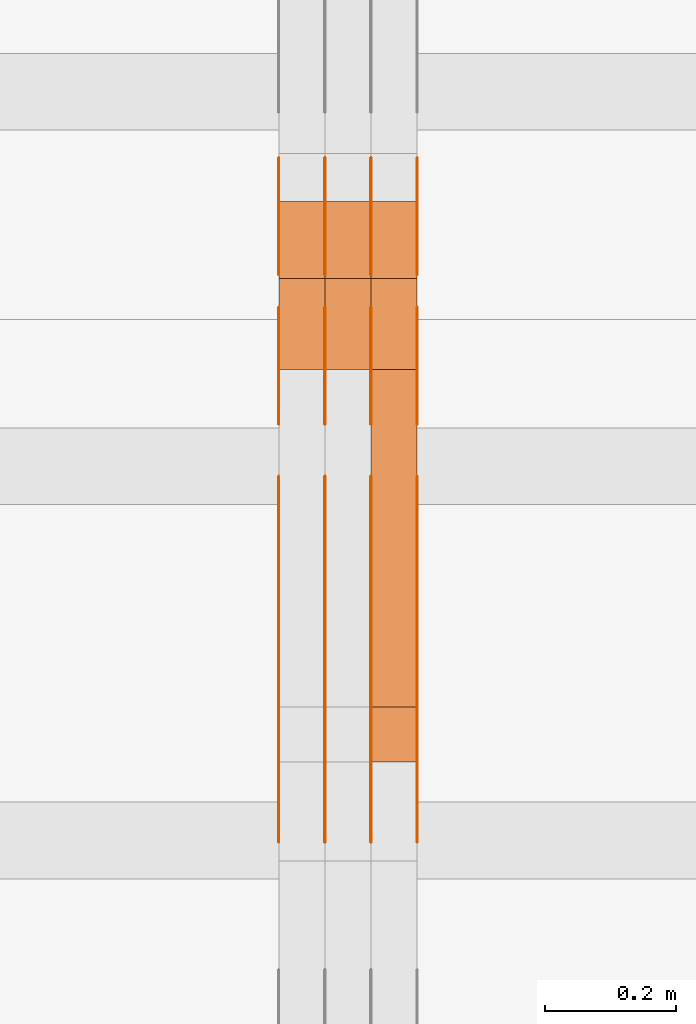
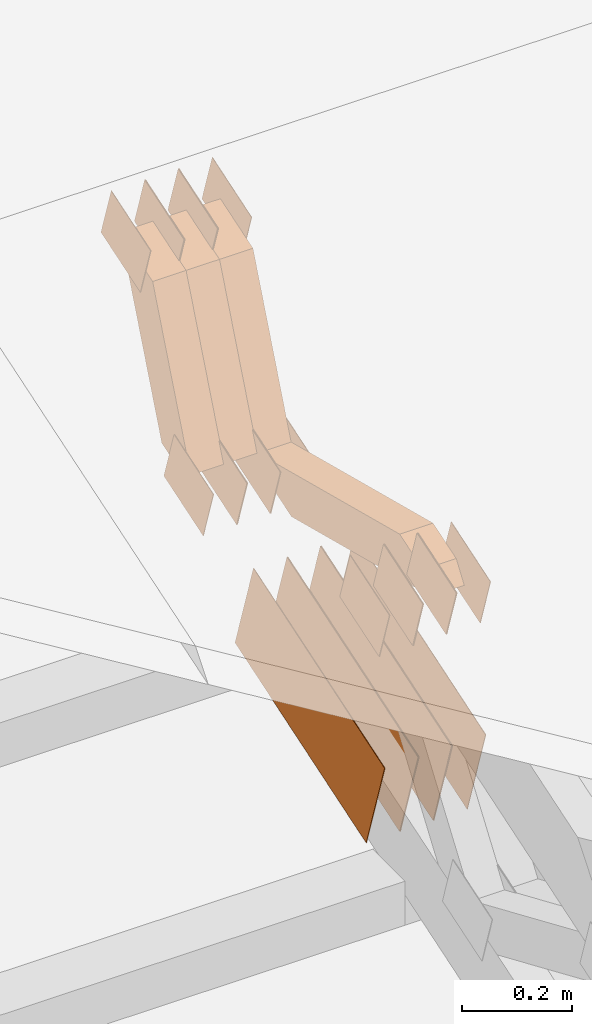
# One storey, part 134 of 385: 28 proxies.
"""IFC2X3 building model written with IfcOpenShell, lengths in millimetres."""

from ifc_helpers import new_model, entity, si_unit, converted_unit, derived_unit, direction, frame, origin, place, context, subcontext, project, spatial, polyline, outline, extrude, source, transform, mapped, material, type_object, type_shapes, element, save


model = new_model("IFC2X3")

# Units and contexts
model_context = context("Model", 3, precision=0.01, world=origin(), true_north=direction((6.12303176911189e-17, 1.0)))
body_context = subcontext(model_context, "Body", "Model", "MODEL_VIEW")
ifc_project = project(units=[si_unit("LENGTHUNIT", "METRE", prefix="MILLI"), si_unit("AREAUNIT", "SQUARE_METRE"), si_unit("VOLUMEUNIT", "CUBIC_METRE"), converted_unit("PLANEANGLEUNIT", "DEGREE", entity("IfcRatioMeasure", 0.0174532925199433), si_unit("PLANEANGLEUNIT", "RADIAN"), dimensions=[0, 0, 0, 0, 0, 0, 0]), si_unit("MASSUNIT", "GRAM", prefix="KILO"), derived_unit("MASSDENSITYUNIT", [(si_unit("MASSUNIT", "GRAM", prefix="KILO"), 1), (si_unit("LENGTHUNIT", "METRE"), -3)]), si_unit("TIMEUNIT", "SECOND"), si_unit("FREQUENCYUNIT", "HERTZ"), si_unit("THERMODYNAMICTEMPERATUREUNIT", "DEGREE_CELSIUS"), derived_unit("THERMALTRANSMITTANCEUNIT", [(si_unit("MASSUNIT", "GRAM", prefix="KILO"), 1), (si_unit("THERMODYNAMICTEMPERATUREUNIT", "KELVIN"), -1), (si_unit("TIMEUNIT", "SECOND"), -3)]), derived_unit("VOLUMETRICFLOWRATEUNIT", [(si_unit("LENGTHUNIT", "METRE"), 3), (si_unit("TIMEUNIT", "SECOND"), -1)]), si_unit("ELECTRICCURRENTUNIT", "AMPERE"), si_unit("ELECTRICVOLTAGEUNIT", "VOLT"), si_unit("POWERUNIT", "WATT"), si_unit("FORCEUNIT", "NEWTON", prefix="KILO"), si_unit("ILLUMINANCEUNIT", "LUX"), si_unit("LUMINOUSFLUXUNIT", "LUMEN"), si_unit("LUMINOUSINTENSITYUNIT", "CANDELA"), derived_unit("USERDEFINED", [(si_unit("MASSUNIT", "GRAM", prefix="KILO"), -1), (si_unit("LENGTHUNIT", "METRE"), -2), (si_unit("TIMEUNIT", "SECOND"), 3), (si_unit("LUMINOUSFLUXUNIT", "LUMEN"), 1)]), derived_unit("LINEARVELOCITYUNIT", [(si_unit("LENGTHUNIT", "METRE"), 1), (si_unit("TIMEUNIT", "SECOND"), -1)]), si_unit("PRESSUREUNIT", "PASCAL"), derived_unit("USERDEFINED", [(si_unit("LENGTHUNIT", "METRE"), -2), (si_unit("MASSUNIT", "GRAM", prefix="KILO"), 1), (si_unit("TIMEUNIT", "SECOND"), -2)])], contexts=[model_context])

# Site, building, storey
site_placement = place(None, origin())
site = spatial("IfcSite", under=ifc_project, at=site_placement, CompositionType="ELEMENT")
building_placement = place(site_placement, origin())
building = spatial("IfcBuilding", under=site, at=building_placement, CompositionType="ELEMENT")
storey_placement = place(building_placement, origin())
storey = spatial("IfcBuildingStorey", under=building, at=storey_placement, Name="Default", CompositionType="ELEMENT", Elevation=0.0)

# Proxies
ifc_material_1 = material(Name="IfcSurfaceStyle #350630")
building_element_proxy_type_1 = type_object("IfcBuildingElementProxyType", PredefinedType="NOTDEFINED", material=ifc_material_1)
shared_shape_1 = source(origin(), body_context, "Body", "SweptSolid", [
    extrude(outline(polyline([(-74.9998565677179, -60.000059685226), (74.9998794200128, -60.000059685226), (74.9998565677179, 60.000059685226), (-74.9998794200128, 60.000059685226), (-74.9998565677179, -60.000059685226)])), frame((75.0001976720505, 60.000059685226, 0.0), z_axis=(0.0, 0.0, 1.0), x_axis=(-1.0, 0.0, 0.0)), (0.0, 0.0, 1.0), 1.3),
])
type_shapes(building_element_proxy_type_1, [shared_shape_1])
proxy_1_placement = place(building_placement, frame((27386.3, 8537.53090236182, 1950.11166041942), z_axis=(-1.0, 0.0, 0.0), x_axis=(0.0, 0.951056516295124, 0.309016994375039)))
element("IfcBuildingElementProxy", 1, at=proxy_1_placement, inside=storey, type_object=building_element_proxy_type_1, material=ifc_material_1, context=body_context, shape_type="MappedRepresentation", body=[
    mapped(shared_shape_1, transform((0.0, 0.0, 0.0), scale=1.0)),
])
ifc_material_2 = material(Name="IfcSurfaceStyle #350573")
building_element_proxy_type_2 = type_object("IfcBuildingElementProxyType", PredefinedType="NOTDEFINED", material=ifc_material_2)
shared_shape_2 = source(origin(), body_context, "Body", "SweptSolid", [
    extrude(outline(polyline([(-74.9998565677179, -60.000059685226), (74.9998794200128, -60.000059685226), (74.9998565677179, 60.000059685226), (-74.9998794200128, 60.000059685226), (-74.9998565677179, -60.000059685226)])), frame((75.0001976720505, 60.000059685226, 0.0), z_axis=(0.0, 0.0, 1.0), x_axis=(-1.0, 0.0, 0.0)), (0.0, 0.0, 1.0), 1.3),
])
type_shapes(building_element_proxy_type_2, [shared_shape_2])
proxy_2_placement = place(building_placement, frame((27315.0, 8537.53090236182, 1950.11166041942), z_axis=(-1.0, 0.0, 0.0), x_axis=(0.0, 0.951056516295124, 0.309016994375039)))
element("IfcBuildingElementProxy", 2, at=proxy_2_placement, inside=storey, type_object=building_element_proxy_type_2, material=ifc_material_2, context=body_context, shape_type="MappedRepresentation", body=[
    mapped(shared_shape_2, transform((0.0, 0.0, 0.0), scale=1.0)),
])
ifc_material_3 = material(Name="IfcSurfaceStyle #350516")
building_element_proxy_type_3 = type_object("IfcBuildingElementProxyType", PredefinedType="NOTDEFINED", material=ifc_material_3)
shared_shape_3 = source(origin(), body_context, "Body", "SweptSolid", [
    extrude(outline(polyline([(-74.9998565677179, -60.000059685226), (74.9998794200128, -60.000059685226), (74.9998565677179, 60.000059685226), (-74.9998794200128, 60.000059685226), (-74.9998565677179, -60.000059685226)])), frame((75.0001976720505, 60.000059685226, 0.0), z_axis=(0.0, 0.0, 1.0), x_axis=(-1.0, 0.0, 0.0)), (0.0, 0.0, 1.0), 1.3),
])
type_shapes(building_element_proxy_type_3, [shared_shape_3])
proxy_3_placement = place(building_placement, frame((27316.3, 8537.53090236182, 1950.11166041942), z_axis=(-1.0, 0.0, 0.0), x_axis=(0.0, 0.951056516295124, 0.309016994375039)))
element("IfcBuildingElementProxy", 3, at=proxy_3_placement, inside=storey, type_object=building_element_proxy_type_3, material=ifc_material_3, context=body_context, shape_type="MappedRepresentation", body=[
    mapped(shared_shape_3, transform((0.0, 0.0, 0.0), scale=1.0)),
])
ifc_material_4 = material(Name="IfcSurfaceStyle #350459")
building_element_proxy_type_4 = type_object("IfcBuildingElementProxyType", PredefinedType="NOTDEFINED", material=ifc_material_4)
shared_shape_4 = source(origin(), body_context, "Body", "SweptSolid", [
    extrude(outline(polyline([(-74.9998565677179, -60.000059685226), (74.9998794200128, -60.000059685226), (74.9998565677179, 60.000059685226), (-74.9998794200128, 60.000059685226), (-74.9998565677179, -60.000059685226)])), frame((75.0001976720505, 60.000059685226, 0.0), z_axis=(0.0, 0.0, 1.0), x_axis=(-1.0, 0.0, 0.0)), (0.0, 0.0, 1.0), 1.29999999999999),
])
type_shapes(building_element_proxy_type_4, [shared_shape_4])
proxy_4_placement = place(building_placement, frame((27245.0, 8537.53090236182, 1950.11166041942), z_axis=(-1.0, 0.0, 0.0), x_axis=(0.0, 0.951056516295124, 0.309016994375039)))
element("IfcBuildingElementProxy", 4, at=proxy_4_placement, inside=storey, type_object=building_element_proxy_type_4, material=ifc_material_4, context=body_context, shape_type="MappedRepresentation", body=[
    mapped(shared_shape_4, transform((0.0, 0.0, 0.0), scale=1.0)),
])
ifc_material_5 = material(Name="IfcSurfaceStyle #350402")
building_element_proxy_type_5 = type_object("IfcBuildingElementProxyType", PredefinedType="NOTDEFINED", material=ifc_material_5)
shared_shape_5 = source(origin(), body_context, "Body", "SweptSolid", [
    extrude(outline(polyline([(-74.9998565677179, -60.000059685226), (74.9998794200128, -60.000059685226), (74.9998565677179, 60.000059685226), (-74.9998794200128, 60.000059685226), (-74.9998565677179, -60.000059685226)])), frame((75.0001976720505, 60.000059685226, 0.0), z_axis=(0.0, 0.0, 1.0), x_axis=(-1.0, 0.0, 0.0)), (0.0, 0.0, 1.0), 1.29999999999999),
])
type_shapes(building_element_proxy_type_5, [shared_shape_5])
proxy_5_placement = place(building_placement, frame((27246.3, 8537.53090236182, 1950.11166041942), z_axis=(-1.0, 0.0, 0.0), x_axis=(0.0, 0.951056516295124, 0.309016994375039)))
element("IfcBuildingElementProxy", 5, at=proxy_5_placement, inside=storey, type_object=building_element_proxy_type_5, material=ifc_material_5, context=body_context, shape_type="MappedRepresentation", body=[
    mapped(shared_shape_5, transform((0.0, 0.0, 0.0), scale=1.0)),
])
ifc_material_6 = material(Name="IfcSurfaceStyle #350345")
building_element_proxy_type_6 = type_object("IfcBuildingElementProxyType", PredefinedType="NOTDEFINED", material=ifc_material_6)
shared_shape_6 = source(origin(), body_context, "Body", "SweptSolid", [
    extrude(outline(polyline([(-74.9998565677179, -60.000059685226), (74.9998794200128, -60.000059685226), (74.9998565677179, 60.000059685226), (-74.9998794200128, 60.000059685226), (-74.9998565677179, -60.000059685226)])), frame((75.0001976720505, 60.000059685226, 0.0), z_axis=(0.0, 0.0, 1.0), x_axis=(-1.0, 0.0, 0.0)), (0.0, 0.0, 1.0), 1.29999999999999),
])
type_shapes(building_element_proxy_type_6, [shared_shape_6])
proxy_6_placement = place(building_placement, frame((27175.0, 8537.53090236182, 1950.11166041942), z_axis=(-1.0, 0.0, 0.0), x_axis=(0.0, 0.951056516295124, 0.309016994375039)))
element("IfcBuildingElementProxy", 6, at=proxy_6_placement, inside=storey, type_object=building_element_proxy_type_6, material=ifc_material_6, context=body_context, shape_type="MappedRepresentation", body=[
    mapped(shared_shape_6, transform((0.0, 0.0, 0.0), scale=1.0)),
])
ifc_material_7 = material(Name="IfcSurfaceStyle #350288")
building_element_proxy_type_7 = type_object("IfcBuildingElementProxyType", PredefinedType="NOTDEFINED", material=ifc_material_7)
shared_shape_7 = source(origin(), body_context, "Body", "SweptSolid", [
    extrude(outline(polyline([(-74.9998754286225, -60.0000016373515), (74.9998605591045, -60.0000016373515), (74.9998754286225, 60.0000016373515), (-74.9998605591045, 60.0000016373515), (-74.9998754286225, -60.0000016373515)])), frame((74.9998754286225, 60.0000016373515, 0.0), z_axis=(0.0, 0.0, 1.0), x_axis=(-1.0, 0.0, 0.0)), (0.0, 0.0, 1.0), 1.3),
])
type_shapes(building_element_proxy_type_7, [shared_shape_7])
proxy_7_placement = place(building_placement, frame((27386.3, 8765.47458614632, 2350.86432930304), z_axis=(-1.0, 0.0, 0.0), x_axis=(0.0, 0.951056516295154, 0.309016994374948)))
element("IfcBuildingElementProxy", 7, at=proxy_7_placement, inside=storey, type_object=building_element_proxy_type_7, material=ifc_material_7, context=body_context, shape_type="MappedRepresentation", body=[
    mapped(shared_shape_7, transform((0.0, 0.0, 0.0), scale=1.0)),
])
ifc_material_8 = material(Name="IfcSurfaceStyle #350231")
building_element_proxy_type_8 = type_object("IfcBuildingElementProxyType", PredefinedType="NOTDEFINED", material=ifc_material_8)
shared_shape_8 = source(origin(), body_context, "Body", "SweptSolid", [
    extrude(outline(polyline([(-74.9998754286225, -60.0000016373515), (74.9998605591045, -60.0000016373515), (74.9998754286225, 60.0000016373515), (-74.9998605591045, 60.0000016373515), (-74.9998754286225, -60.0000016373515)])), frame((74.9998754286225, 60.0000016373515, 0.0), z_axis=(0.0, 0.0, 1.0), x_axis=(-1.0, 0.0, 0.0)), (0.0, 0.0, 1.0), 1.3),
])
type_shapes(building_element_proxy_type_8, [shared_shape_8])
proxy_8_placement = place(building_placement, frame((27315.0, 8765.47458614632, 2350.86432930304), z_axis=(-1.0, 0.0, 0.0), x_axis=(0.0, 0.951056516295154, 0.309016994374948)))
element("IfcBuildingElementProxy", 8, at=proxy_8_placement, inside=storey, type_object=building_element_proxy_type_8, material=ifc_material_8, context=body_context, shape_type="MappedRepresentation", body=[
    mapped(shared_shape_8, transform((0.0, 0.0, 0.0), scale=1.0)),
])
ifc_material_9 = material(Name="IfcSurfaceStyle #350174")
building_element_proxy_type_9 = type_object("IfcBuildingElementProxyType", PredefinedType="NOTDEFINED", material=ifc_material_9)
shared_shape_9 = source(origin(), body_context, "Body", "SweptSolid", [
    extrude(outline(polyline([(-74.9998754286225, -60.0000016373515), (74.9998605591045, -60.0000016373515), (74.9998754286225, 60.0000016373515), (-74.9998605591045, 60.0000016373515), (-74.9998754286225, -60.0000016373515)])), frame((74.9998754286225, 60.0000016373515, 0.0), z_axis=(0.0, 0.0, 1.0), x_axis=(-1.0, 0.0, 0.0)), (0.0, 0.0, 1.0), 1.3),
])
type_shapes(building_element_proxy_type_9, [shared_shape_9])
proxy_9_placement = place(building_placement, frame((27316.3, 8765.47458614632, 2350.86432930304), z_axis=(-1.0, 0.0, 0.0), x_axis=(0.0, 0.951056516295154, 0.309016994374948)))
element("IfcBuildingElementProxy", 9, at=proxy_9_placement, inside=storey, type_object=building_element_proxy_type_9, material=ifc_material_9, context=body_context, shape_type="MappedRepresentation", body=[
    mapped(shared_shape_9, transform((0.0, 0.0, 0.0), scale=1.0)),
])
ifc_material_10 = material(Name="IfcSurfaceStyle #350117")
building_element_proxy_type_10 = type_object("IfcBuildingElementProxyType", PredefinedType="NOTDEFINED", material=ifc_material_10)
shared_shape_10 = source(origin(), body_context, "Body", "SweptSolid", [
    extrude(outline(polyline([(-74.9998754286225, -60.0000016373515), (74.9998605591045, -60.0000016373515), (74.9998754286225, 60.0000016373515), (-74.9998605591045, 60.0000016373515), (-74.9998754286225, -60.0000016373515)])), frame((74.9998754286225, 60.0000016373515, 0.0), z_axis=(0.0, 0.0, 1.0), x_axis=(-1.0, 0.0, 0.0)), (0.0, 0.0, 1.0), 1.29999999999999),
])
type_shapes(building_element_proxy_type_10, [shared_shape_10])
proxy_10_placement = place(building_placement, frame((27245.0, 8765.47458614632, 2350.86432930304), z_axis=(-1.0, 0.0, 0.0), x_axis=(0.0, 0.951056516295154, 0.309016994374948)))
element("IfcBuildingElementProxy", 10, at=proxy_10_placement, inside=storey, type_object=building_element_proxy_type_10, material=ifc_material_10, context=body_context, shape_type="MappedRepresentation", body=[
    mapped(shared_shape_10, transform((0.0, 0.0, 0.0), scale=1.0)),
])
ifc_material_11 = material(Name="IfcSurfaceStyle #350060")
building_element_proxy_type_11 = type_object("IfcBuildingElementProxyType", PredefinedType="NOTDEFINED", material=ifc_material_11)
shared_shape_11 = source(origin(), body_context, "Body", "SweptSolid", [
    extrude(outline(polyline([(-74.9998754286225, -60.0000016373515), (74.9998605591045, -60.0000016373515), (74.9998754286225, 60.0000016373515), (-74.9998605591045, 60.0000016373515), (-74.9998754286225, -60.0000016373515)])), frame((74.9998754286225, 60.0000016373515, 0.0), z_axis=(0.0, 0.0, 1.0), x_axis=(-1.0, 0.0, 0.0)), (0.0, 0.0, 1.0), 1.29999999999999),
])
type_shapes(building_element_proxy_type_11, [shared_shape_11])
proxy_11_placement = place(building_placement, frame((27246.3, 8765.47458614632, 2350.86432930304), z_axis=(-1.0, 0.0, 0.0), x_axis=(0.0, 0.951056516295154, 0.309016994374948)))
element("IfcBuildingElementProxy", 11, at=proxy_11_placement, inside=storey, type_object=building_element_proxy_type_11, material=ifc_material_11, context=body_context, shape_type="MappedRepresentation", body=[
    mapped(shared_shape_11, transform((0.0, 0.0, 0.0), scale=1.0)),
])
ifc_material_12 = material(Name="IfcSurfaceStyle #350003")
building_element_proxy_type_12 = type_object("IfcBuildingElementProxyType", PredefinedType="NOTDEFINED", material=ifc_material_12)
shared_shape_12 = source(origin(), body_context, "Body", "SweptSolid", [
    extrude(outline(polyline([(-74.9998754286225, -60.0000016373515), (74.9998605591045, -60.0000016373515), (74.9998754286225, 60.0000016373515), (-74.9998605591045, 60.0000016373515), (-74.9998754286225, -60.0000016373515)])), frame((74.9998754286225, 60.0000016373515, 0.0), z_axis=(0.0, 0.0, 1.0), x_axis=(-1.0, 0.0, 0.0)), (0.0, 0.0, 1.0), 1.29999999999999),
])
type_shapes(building_element_proxy_type_12, [shared_shape_12])
proxy_12_placement = place(building_placement, frame((27175.0, 8765.47458614632, 2350.86432930304), z_axis=(-1.0, 0.0, 0.0), x_axis=(0.0, 0.951056516295154, 0.309016994374948)))
element("IfcBuildingElementProxy", 12, at=proxy_12_placement, inside=storey, type_object=building_element_proxy_type_12, material=ifc_material_12, context=body_context, shape_type="MappedRepresentation", body=[
    mapped(shared_shape_12, transform((0.0, 0.0, 0.0), scale=1.0)),
])
ifc_material_13 = material(Name="IfcSurfaceStyle #349604")
building_element_proxy_type_13 = type_object("IfcBuildingElementProxyType", PredefinedType="NOTDEFINED", material=ifc_material_13)
shared_shape_13 = source(origin(), body_context, "Body", "SweptSolid", [
    extrude(outline(polyline([(-249.999749056184, -108.000229288163), (249.999396050782, -108.000229288163), (249.999749056184, 108.000229288163), (-249.999396050782, 108.000229288163), (-249.999749056184, -108.000229288163)])), frame((249.999841104007, 108.000229288163, 0.0), z_axis=(0.0, 0.0, 1.0), x_axis=(-1.0, 0.0, 0.0)), (0.0, 0.0, 1.0), 1.29999999999998),
])
type_shapes(building_element_proxy_type_13, [shared_shape_13])
proxy_13_placement = place(building_placement, frame((27386.3, 7917.13457673635, 1720.66532252899), z_axis=(-1.0, 0.0, 0.0), x_axis=(0.0, 0.951056516295124, 0.309016994375039)))
element("IfcBuildingElementProxy", 13, at=proxy_13_placement, inside=storey, type_object=building_element_proxy_type_13, material=ifc_material_13, context=body_context, shape_type="MappedRepresentation", body=[
    mapped(shared_shape_13, transform((0.0, 0.0, 0.0), scale=1.0)),
])
ifc_material_14 = material(Name="IfcSurfaceStyle #349547")
building_element_proxy_type_14 = type_object("IfcBuildingElementProxyType", PredefinedType="NOTDEFINED", material=ifc_material_14)
shared_shape_14 = source(origin(), body_context, "Body", "SweptSolid", [
    extrude(outline(polyline([(-249.999749056184, -108.000229288163), (249.999396050782, -108.000229288163), (249.999749056184, 108.000229288163), (-249.999396050782, 108.000229288163), (-249.999749056184, -108.000229288163)])), frame((249.999841104007, 108.000229288163, 0.0), z_axis=(0.0, 0.0, 1.0), x_axis=(-1.0, 0.0, 0.0)), (0.0, 0.0, 1.0), 1.29999999999998),
])
type_shapes(building_element_proxy_type_14, [shared_shape_14])
proxy_14_placement = place(building_placement, frame((27315.0, 7917.13457673635, 1720.66532252899), z_axis=(-1.0, 0.0, 0.0), x_axis=(0.0, 0.951056516295124, 0.309016994375039)))
element("IfcBuildingElementProxy", 14, at=proxy_14_placement, inside=storey, type_object=building_element_proxy_type_14, material=ifc_material_14, context=body_context, shape_type="MappedRepresentation", body=[
    mapped(shared_shape_14, transform((0.0, 0.0, 0.0), scale=1.0)),
])
ifc_material_15 = material(Name="IfcSurfaceStyle #349490")
building_element_proxy_type_15 = type_object("IfcBuildingElementProxyType", PredefinedType="NOTDEFINED", material=ifc_material_15)
shared_shape_15 = source(origin(), body_context, "Body", "SweptSolid", [
    extrude(outline(polyline([(-249.999749056184, -108.000229288163), (249.999396050782, -108.000229288163), (249.999749056184, 108.000229288163), (-249.999396050782, 108.000229288163), (-249.999749056184, -108.000229288163)])), frame((249.999841104007, 108.000229288163, 0.0), z_axis=(0.0, 0.0, 1.0), x_axis=(-1.0, 0.0, 0.0)), (0.0, 0.0, 1.0), 1.29999999999998),
])
type_shapes(building_element_proxy_type_15, [shared_shape_15])
proxy_15_placement = place(building_placement, frame((27316.3, 7917.13457673635, 1720.66532252899), z_axis=(-1.0, 0.0, 0.0), x_axis=(0.0, 0.951056516295124, 0.309016994375039)))
element("IfcBuildingElementProxy", 15, at=proxy_15_placement, inside=storey, type_object=building_element_proxy_type_15, material=ifc_material_15, context=body_context, shape_type="MappedRepresentation", body=[
    mapped(shared_shape_15, transform((0.0, 0.0, 0.0), scale=1.0)),
])
ifc_material_16 = material(Name="IfcSurfaceStyle #349433")
building_element_proxy_type_16 = type_object("IfcBuildingElementProxyType", PredefinedType="NOTDEFINED", material=ifc_material_16)
shared_shape_16 = source(origin(), body_context, "Body", "SweptSolid", [
    extrude(outline(polyline([(-249.999749056184, -108.000229288163), (249.999396050782, -108.000229288163), (249.999749056184, 108.000229288163), (-249.999396050782, 108.000229288163), (-249.999749056184, -108.000229288163)])), frame((249.999841104007, 108.000229288163, 0.0), z_axis=(0.0, 0.0, 1.0), x_axis=(-1.0, 0.0, 0.0)), (0.0, 0.0, 1.0), 1.29999999999997),
])
type_shapes(building_element_proxy_type_16, [shared_shape_16])
proxy_16_placement = place(building_placement, frame((27245.0, 7917.13457673635, 1720.66532252899), z_axis=(-1.0, 0.0, 0.0), x_axis=(0.0, 0.951056516295124, 0.309016994375039)))
element("IfcBuildingElementProxy", 16, at=proxy_16_placement, inside=storey, type_object=building_element_proxy_type_16, material=ifc_material_16, context=body_context, shape_type="MappedRepresentation", body=[
    mapped(shared_shape_16, transform((0.0, 0.0, 0.0), scale=1.0)),
])
ifc_material_17 = material(Name="IfcSurfaceStyle #349376")
building_element_proxy_type_17 = type_object("IfcBuildingElementProxyType", PredefinedType="NOTDEFINED", material=ifc_material_17)
shared_shape_17 = source(origin(), body_context, "Body", "SweptSolid", [
    extrude(outline(polyline([(-249.999749056184, -108.000229288163), (249.999396050782, -108.000229288163), (249.999749056184, 108.000229288163), (-249.999396050782, 108.000229288163), (-249.999749056184, -108.000229288163)])), frame((249.999841104007, 108.000229288163, 0.0), z_axis=(0.0, 0.0, 1.0), x_axis=(-1.0, 0.0, 0.0)), (0.0, 0.0, 1.0), 1.29999999999997),
])
type_shapes(building_element_proxy_type_17, [shared_shape_17])
proxy_17_placement = place(building_placement, frame((27246.3, 7917.13457673635, 1720.66532252899), z_axis=(-1.0, 0.0, 0.0), x_axis=(0.0, 0.951056516295124, 0.309016994375039)))
element("IfcBuildingElementProxy", 17, at=proxy_17_placement, inside=storey, type_object=building_element_proxy_type_17, material=ifc_material_17, context=body_context, shape_type="MappedRepresentation", body=[
    mapped(shared_shape_17, transform((0.0, 0.0, 0.0), scale=1.0)),
])
ifc_material_18 = material(Name="IfcSurfaceStyle #349319")
building_element_proxy_type_18 = type_object("IfcBuildingElementProxyType", PredefinedType="NOTDEFINED", material=ifc_material_18)
shared_shape_18 = source(origin(), body_context, "Body", "SweptSolid", [
    extrude(outline(polyline([(-249.999749056184, -108.000229288163), (249.999396050782, -108.000229288163), (249.999749056184, 108.000229288163), (-249.999396050782, 108.000229288163), (-249.999749056184, -108.000229288163)])), frame((249.999841104007, 108.000229288163, 0.0), z_axis=(0.0, 0.0, 1.0), x_axis=(-1.0, 0.0, 0.0)), (0.0, 0.0, 1.0), 1.29999999999997),
])
type_shapes(building_element_proxy_type_18, [shared_shape_18])
proxy_18_placement = place(building_placement, frame((27175.0, 7917.13457673635, 1720.66532252899), z_axis=(-1.0, 0.0, 0.0), x_axis=(0.0, 0.951056516295124, 0.309016994375039)))
element("IfcBuildingElementProxy", 18, at=proxy_18_placement, inside=storey, type_object=building_element_proxy_type_18, material=ifc_material_18, context=body_context, shape_type="MappedRepresentation", body=[
    mapped(shared_shape_18, transform((0.0, 0.0, 0.0), scale=1.0)),
])
ifc_material_19 = material(Name="IfcSurfaceStyle #335924")
building_element_proxy_type_19 = type_object("IfcBuildingElementProxyType", PredefinedType="NOTDEFINED", material=ifc_material_19)
shared_shape_19 = source(origin(), body_context, "Body", "SweptSolid", [
    extrude(outline(polyline([(-74.9998754286253, -60.0000016373506), (74.9998605591091, -60.0000016373506), (74.9998754286234, 60.0000016373506), (-74.9998605591072, 60.0000016373506), (-74.9998754286253, -60.0000016373506)])), frame((75.0007355357002, 60.0002637031812, 0.0), z_axis=(0.0, 0.0, 1.0), x_axis=(-1.0, 0.0, 0.0)), (0.0, 0.0, 1.0), 1.3),
])
type_shapes(building_element_proxy_type_19, [shared_shape_19])
proxy_19_placement = place(building_placement, frame((27386.3, 7899.79204652809, 2069.58672486412), z_axis=(-1.0, 0.0, 0.0), x_axis=(0.0, 0.951056516295154, 0.309016994374948)))
element("IfcBuildingElementProxy", 19, at=proxy_19_placement, inside=storey, type_object=building_element_proxy_type_19, material=ifc_material_19, context=body_context, shape_type="MappedRepresentation", body=[
    mapped(shared_shape_19, transform((0.0, 0.0, 0.0), scale=1.0)),
])
ifc_material_20 = material(Name="IfcSurfaceStyle #335867")
building_element_proxy_type_20 = type_object("IfcBuildingElementProxyType", PredefinedType="NOTDEFINED", material=ifc_material_20)
shared_shape_20 = source(origin(), body_context, "Body", "SweptSolid", [
    extrude(outline(polyline([(-74.9998754286253, -60.0000016373506), (74.9998605591091, -60.0000016373506), (74.9998754286234, 60.0000016373506), (-74.9998605591072, 60.0000016373506), (-74.9998754286253, -60.0000016373506)])), frame((75.0007355357002, 60.0002637031812, 0.0), z_axis=(0.0, 0.0, 1.0), x_axis=(-1.0, 0.0, 0.0)), (0.0, 0.0, 1.0), 1.3),
])
type_shapes(building_element_proxy_type_20, [shared_shape_20])
proxy_20_placement = place(building_placement, frame((27315.0, 7899.79204652809, 2069.58672486412), z_axis=(-1.0, 0.0, 0.0), x_axis=(0.0, 0.951056516295154, 0.309016994374948)))
element("IfcBuildingElementProxy", 20, at=proxy_20_placement, inside=storey, type_object=building_element_proxy_type_20, material=ifc_material_20, context=body_context, shape_type="MappedRepresentation", body=[
    mapped(shared_shape_20, transform((0.0, 0.0, 0.0), scale=1.0)),
])
ifc_material_21 = material(Name="IfcSurfaceStyle #335810")
building_element_proxy_type_21 = type_object("IfcBuildingElementProxyType", PredefinedType="NOTDEFINED", material=ifc_material_21)
shared_shape_21 = source(origin(), body_context, "Body", "SweptSolid", [
    extrude(outline(polyline([(-74.9998754286253, -60.0000016373506), (74.9998605591091, -60.0000016373506), (74.9998754286234, 60.0000016373506), (-74.9998605591072, 60.0000016373506), (-74.9998754286253, -60.0000016373506)])), frame((75.0007355357002, 60.0002637031812, 0.0), z_axis=(0.0, 0.0, 1.0), x_axis=(-1.0, 0.0, 0.0)), (0.0, 0.0, 1.0), 1.3),
])
type_shapes(building_element_proxy_type_21, [shared_shape_21])
proxy_21_placement = place(building_placement, frame((27316.3, 7899.79204652809, 2069.58672486412), z_axis=(-1.0, 0.0, 0.0), x_axis=(0.0, 0.951056516295154, 0.309016994374948)))
element("IfcBuildingElementProxy", 21, at=proxy_21_placement, inside=storey, type_object=building_element_proxy_type_21, material=ifc_material_21, context=body_context, shape_type="MappedRepresentation", body=[
    mapped(shared_shape_21, transform((0.0, 0.0, 0.0), scale=1.0)),
])
ifc_material_22 = material(Name="IfcSurfaceStyle #335753")
building_element_proxy_type_22 = type_object("IfcBuildingElementProxyType", PredefinedType="NOTDEFINED", material=ifc_material_22)
shared_shape_22 = source(origin(), body_context, "Body", "SweptSolid", [
    extrude(outline(polyline([(-74.9998754286253, -60.0000016373506), (74.9998605591091, -60.0000016373506), (74.9998754286234, 60.0000016373506), (-74.9998605591072, 60.0000016373506), (-74.9998754286253, -60.0000016373506)])), frame((75.0007355357002, 60.0002637031812, 0.0), z_axis=(0.0, 0.0, 1.0), x_axis=(-1.0, 0.0, 0.0)), (0.0, 0.0, 1.0), 1.29999999999999),
])
type_shapes(building_element_proxy_type_22, [shared_shape_22])
proxy_22_placement = place(building_placement, frame((27245.0, 7899.79204652809, 2069.58672486412), z_axis=(-1.0, 0.0, 0.0), x_axis=(0.0, 0.951056516295154, 0.309016994374948)))
element("IfcBuildingElementProxy", 22, at=proxy_22_placement, inside=storey, type_object=building_element_proxy_type_22, material=ifc_material_22, context=body_context, shape_type="MappedRepresentation", body=[
    mapped(shared_shape_22, transform((0.0, 0.0, 0.0), scale=1.0)),
])
ifc_material_23 = material(Name="IfcSurfaceStyle #335696")
building_element_proxy_type_23 = type_object("IfcBuildingElementProxyType", PredefinedType="NOTDEFINED", material=ifc_material_23)
shared_shape_23 = source(origin(), body_context, "Body", "SweptSolid", [
    extrude(outline(polyline([(-74.9998754286253, -60.0000016373506), (74.9998605591091, -60.0000016373506), (74.9998754286234, 60.0000016373506), (-74.9998605591072, 60.0000016373506), (-74.9998754286253, -60.0000016373506)])), frame((75.0007355357002, 60.0002637031812, 0.0), z_axis=(0.0, 0.0, 1.0), x_axis=(-1.0, 0.0, 0.0)), (0.0, 0.0, 1.0), 1.29999999999999),
])
type_shapes(building_element_proxy_type_23, [shared_shape_23])
proxy_23_placement = place(building_placement, frame((27246.3, 7899.79204652809, 2069.58672486412), z_axis=(-1.0, 0.0, 0.0), x_axis=(0.0, 0.951056516295154, 0.309016994374948)))
element("IfcBuildingElementProxy", 23, at=proxy_23_placement, inside=storey, type_object=building_element_proxy_type_23, material=ifc_material_23, context=body_context, shape_type="MappedRepresentation", body=[
    mapped(shared_shape_23, transform((0.0, 0.0, 0.0), scale=1.0)),
])
ifc_material_24 = material(Name="IfcSurfaceStyle #335639")
building_element_proxy_type_24 = type_object("IfcBuildingElementProxyType", PredefinedType="NOTDEFINED", material=ifc_material_24)
shared_shape_24 = source(origin(), body_context, "Body", "SweptSolid", [
    extrude(outline(polyline([(-74.9998754286253, -60.0000016373506), (74.9998605591091, -60.0000016373506), (74.9998754286234, 60.0000016373506), (-74.9998605591072, 60.0000016373506), (-74.9998754286253, -60.0000016373506)])), frame((75.0007355357002, 60.0002637031812, 0.0), z_axis=(0.0, 0.0, 1.0), x_axis=(-1.0, 0.0, 0.0)), (0.0, 0.0, 1.0), 1.29999999999999),
])
type_shapes(building_element_proxy_type_24, [shared_shape_24])
proxy_24_placement = place(building_placement, frame((27175.0, 7899.79204652809, 2069.58672486412), z_axis=(-1.0, 0.0, 0.0), x_axis=(0.0, 0.951056516295154, 0.309016994374948)))
element("IfcBuildingElementProxy", 24, at=proxy_24_placement, inside=storey, type_object=building_element_proxy_type_24, material=ifc_material_24, context=body_context, shape_type="MappedRepresentation", body=[
    mapped(shared_shape_24, transform((0.0, 0.0, 0.0), scale=1.0)),
])
ifc_material_25 = material(Name="IfcSurfaceStyle #323540")
building_element_proxy_type_25 = type_object("IfcBuildingElementProxyType", Name="T1-W45 323538", PredefinedType="NOTDEFINED", material=ifc_material_25)
shared_shape_25 = source(origin(), body_context, "Body", "SweptSolid", [
    extrude(outline(polyline([(-275.953018340717, -47.500197738425), (128.971267956636, -47.5001977384251), (168.669977842085, -0.000132525443043008), (174.867371111815, 47.5002640011466), (-196.55559856982, 47.5002640011466), (-275.953018340717, -47.500197738425)])), frame((174.867371111815, 47.5002640011466, 0.0), z_axis=(0.0, 0.0, 1.0), x_axis=(-1.0, 0.0, 0.0)), (0.0, 0.0, 1.0), 70.0),
])
type_shapes(building_element_proxy_type_25, [shared_shape_25])
proxy_25_placement = place(building_placement, frame((27385.0, 8621.494140625, 1941.33422851563), z_axis=(-1.0, 0.0, 0.0), x_axis=(0.0, 0.372787901688292, 0.927916580493549)))
element("IfcBuildingElementProxy", 25, at=proxy_25_placement, inside=storey, type_object=building_element_proxy_type_25, material=ifc_material_25, Name="T1-W45", context=body_context, shape_type="MappedRepresentation", body=[
    mapped(shared_shape_25, transform((0.0, 0.0, 0.0), scale=1.0)),
])
ifc_material_26 = material(Name="IfcSurfaceStyle #323474")
building_element_proxy_type_26 = type_object("IfcBuildingElementProxyType", Name="T1-W45 323472", PredefinedType="NOTDEFINED", material=ifc_material_26)
shared_shape_26 = source(origin(), body_context, "Body", "SweptSolid", [
    extrude(outline(polyline([(-275.953018340717, -47.500197738425), (128.971267956636, -47.5001977384251), (168.669977842085, -0.000132525443043008), (174.867371111815, 47.5002640011466), (-196.55559856982, 47.5002640011466), (-275.953018340717, -47.500197738425)])), frame((174.867371111815, 47.5002640011466, 0.0), z_axis=(0.0, 0.0, 1.0), x_axis=(-1.0, 0.0, 0.0)), (0.0, 0.0, 1.0), 70.0),
])
type_shapes(building_element_proxy_type_26, [shared_shape_26])
proxy_26_placement = place(building_placement, frame((27315.0, 8621.494140625, 1941.33422851563), z_axis=(-1.0, 0.0, 0.0), x_axis=(0.0, 0.372787901688292, 0.927916580493549)))
element("IfcBuildingElementProxy", 26, at=proxy_26_placement, inside=storey, type_object=building_element_proxy_type_26, material=ifc_material_26, Name="T1-W45", context=body_context, shape_type="MappedRepresentation", body=[
    mapped(shared_shape_26, transform((0.0, 0.0, 0.0), scale=1.0)),
])
ifc_material_27 = material(Name="IfcSurfaceStyle #323408")
building_element_proxy_type_27 = type_object("IfcBuildingElementProxyType", Name="T1-W45 323406", PredefinedType="NOTDEFINED", material=ifc_material_27)
shared_shape_27 = source(origin(), body_context, "Body", "SweptSolid", [
    extrude(outline(polyline([(-275.953018340717, -47.500197738425), (128.971267956636, -47.5001977384251), (168.669977842085, -0.000132525443043008), (174.867371111815, 47.5002640011466), (-196.55559856982, 47.5002640011466), (-275.953018340717, -47.500197738425)])), frame((174.867371111815, 47.5002640011466, 0.0), z_axis=(0.0, 0.0, 1.0), x_axis=(-1.0, 0.0, 0.0)), (0.0, 0.0, 1.0), 70.0),
])
type_shapes(building_element_proxy_type_27, [shared_shape_27])
proxy_27_placement = place(building_placement, frame((27245.0, 8621.494140625, 1941.33422851563), z_axis=(-1.0, 0.0, 0.0), x_axis=(0.0, 0.372787901688292, 0.927916580493549)))
element("IfcBuildingElementProxy", 27, at=proxy_27_placement, inside=storey, type_object=building_element_proxy_type_27, material=ifc_material_27, Name="T1-W45", context=body_context, shape_type="MappedRepresentation", body=[
    mapped(shared_shape_27, transform((0.0, 0.0, 0.0), scale=1.0)),
])
ifc_material_28 = material(Name="IfcSurfaceStyle #323144")
building_element_proxy_type_28 = type_object("IfcBuildingElementProxyType", Name="T1-W11 323142", PredefinedType="NOTDEFINED", material=ifc_material_28)
shared_shape_28 = source(origin(), body_context, "Body", "SweptSolid", [
    extrude(outline(polyline([(-261.366417792209, -47.5000378467523), (260.949520182121, -47.5000378467523), (242.928845159301, -7.41559889341215e-06), (168.237407166939, 47.5000415545517), (-410.749354716152, 47.5000415545517), (-261.366417792209, -47.5000378467523)])), frame((260.949520182121, 47.5000415545517, 0.0), z_axis=(0.0, 0.0, 1.0), x_axis=(-1.0, 0.0, 0.0)), (0.0, 0.0, 1.0), 70.0),
])
type_shapes(building_element_proxy_type_28, [shared_shape_28])
proxy_28_placement = place(building_placement, frame((27385.0, 8017.44318793234, 2097.03832883996), z_axis=(-1.0, 0.0, 0.0), x_axis=(0.0, 0.968347201599873, -0.249607085543851)))
element("IfcBuildingElementProxy", 28, at=proxy_28_placement, inside=storey, type_object=building_element_proxy_type_28, material=ifc_material_28, Name="T1-W11", context=body_context, shape_type="MappedRepresentation", body=[
    mapped(shared_shape_28, transform((0.0, 0.0, 0.0), scale=1.0)),
])

save(model, "model.ifc")
